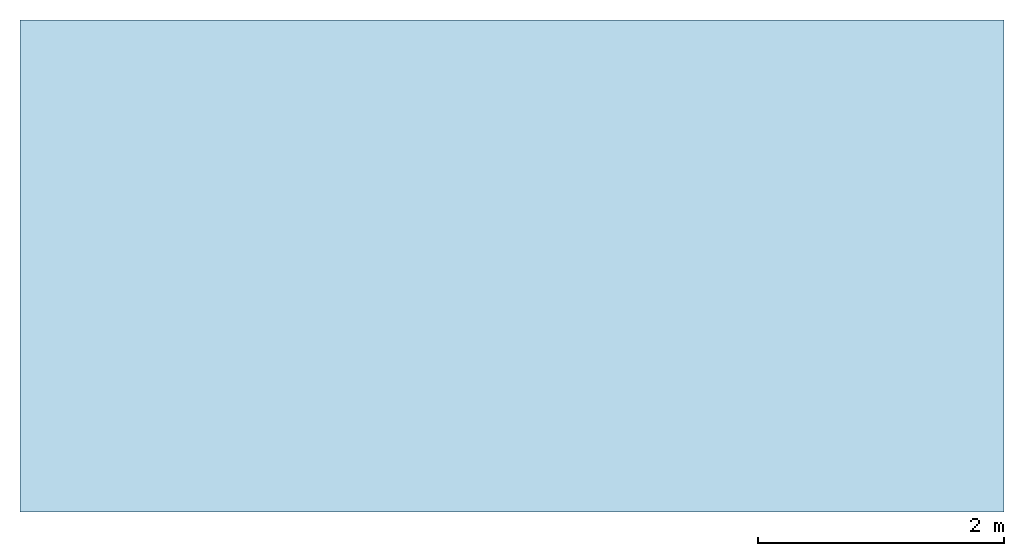
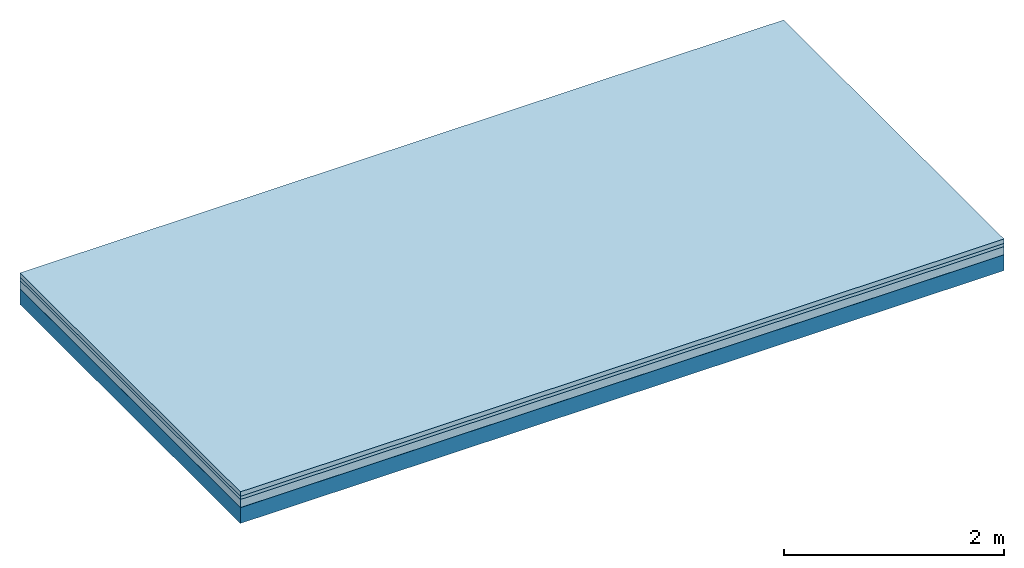
# One storey: 4 plates, 1 member, 1 element without a shape of its own.
"""IFC4 building model written with IfcOpenShell, lengths in metres."""

from ifc_helpers import new_model, si_unit, derived_unit, direction, frame, frame_2d, origin, origin_with_axes, place, context, project, spatial, rectangle, extrude, material, layer, layer_set, type_object, element, aggregate, save


model = new_model("IFC4")

# Units and contexts
plan_context = context("Plan", 3, precision=1e-05, world=origin(), true_north=direction((0.0, 1.0)))
model_context = context("Model", 3, precision=1e-05, world=origin(), true_north=direction((0.0, 1.0)))
ifc_project = project(units=[si_unit("LENGTHUNIT", "METRE"), derived_unit("SOUNDPRESSUREUNIT", [(si_unit("PRESSUREUNIT", "PASCAL", prefix="MICRO"), 0)]), si_unit("ENERGYUNIT", "JOULE", prefix="MEGA"), si_unit("MASSUNIT", "GRAM", prefix="KILO"), derived_unit("THERMALTRANSMITTANCEUNIT", [(si_unit("POWERUNIT", "WATT"), 1), (si_unit("AREAUNIT", "SQUARE_METRE"), -1), (si_unit("THERMODYNAMICTEMPERATUREUNIT", "KELVIN"), -1)]), derived_unit("AREADENSITYUNIT", [(si_unit("MASSUNIT", "GRAM", prefix="KILO"), 1), (si_unit("AREAUNIT", "SQUARE_METRE"), -1)]), derived_unit("USERDEFINED", [(si_unit("ENERGYUNIT", "JOULE", prefix="MEGA"), 1), (si_unit("AREAUNIT", "SQUARE_METRE"), -1)])], contexts=[plan_context, model_context])

# Site, building, storey
site = spatial("IfcSite", under=ifc_project)
building_placement = place(None, origin())
building = spatial("IfcBuilding", under=site, at=building_placement)
storey_placement = place(building_placement, origin())
storey = spatial("IfcBuildingStorey", under=building, at=storey_placement)

# Slab, member, plates
ifc_material_1 = material(Name="Cement screed", Category="04.006")
ifc_layer_1 = layer(ifc_material_1, 0.05, Name="On-material")
ifc_material_2 = material(Name="EP1, 40/35mm")
ifc_layer_2 = layer(ifc_material_2, 0.035, Name="Impact sound insulation")
ifc_material_3 = material(Category="03.011")
ifc_layer_3 = layer(ifc_material_3, 0.09, Name="on Supporting structure")
ifc_material_4 = material(Name="protection", Category="09.007")
ifc_layer_4 = layer(ifc_material_4, 0.0005, Name="Sub-floor")
ifc_material_5 = material(Name="no composite action")
ifc_layer_5 = layer(ifc_material_5, 0.0, Name="Bond")
ifc_layer_6 = layer(None, 0.175, Name="Supporting structure")
ifc_layer_set = layer_set([ifc_layer_1, ifc_layer_2, ifc_layer_3, ifc_layer_4, ifc_layer_5, ifc_layer_6])
slab_type = type_object("IfcSlabType", Name="A2712", PredefinedType="NOTDEFINED", material=ifc_layer_set)
slab_placement = place(None, frame((0.0, 0.0, 0.0), z_axis=(0.0, 0.0, -1.0), x_axis=(1.0, 0.0, 0.0)))
slab = element("IfcSlab", 1, at=slab_placement, inside=storey, type_object=slab_type, material=ifc_layer_set, Name="Slab #1")
ifc_material_6 = material(Name="OSB")
member_placement = place(slab_placement, origin())
member = element("IfcMember", 2, at=member_placement, material=ifc_material_6, Name="Supporting structure", context=plan_context, shape_type="SweptSolid", body=[
    extrude(rectangle(XDim=1.0, YDim=0.175, at=frame_2d((0.5, 0.0875), x_axis=(1.0, 0.0))), frame((0.0, 4.0, 0.1755), z_axis=(0.0, -1.0, 0.0), x_axis=(1.0, 0.0, 0.0)), (0.0, 0.0, 1.0), 4.0),
    extrude(rectangle(XDim=1.0, YDim=0.175, at=frame_2d((0.5, 0.0875), x_axis=(1.0, 0.0))), frame((1.0, 4.0, 0.1755), z_axis=(0.0, -1.0, 0.0), x_axis=(1.0, 0.0, 0.0)), (0.0, 0.0, 1.0), 4.0),
    extrude(rectangle(XDim=1.0, YDim=0.175, at=frame_2d((0.5, 0.0875), x_axis=(1.0, 0.0))), frame((2.0, 4.0, 0.1755), z_axis=(0.0, -1.0, 0.0), x_axis=(1.0, 0.0, 0.0)), (0.0, 0.0, 1.0), 4.0),
    extrude(rectangle(XDim=1.0, YDim=0.175, at=frame_2d((0.5, 0.0875), x_axis=(1.0, 0.0))), frame((3.0, 4.0, 0.1755), z_axis=(0.0, -1.0, 0.0), x_axis=(1.0, 0.0, 0.0)), (0.0, 0.0, 1.0), 4.0),
    extrude(rectangle(XDim=1.0, YDim=0.175, at=frame_2d((0.5, 0.0875), x_axis=(1.0, 0.0))), frame((4.0, 4.0, 0.1755), z_axis=(0.0, -1.0, 0.0), x_axis=(1.0, 0.0, 0.0)), (0.0, 0.0, 1.0), 4.0),
    extrude(rectangle(XDim=1.0, YDim=0.175, at=frame_2d((0.5, 0.0875), x_axis=(1.0, 0.0))), frame((5.0, 4.0, 0.1755), z_axis=(0.0, -1.0, 0.0), x_axis=(1.0, 0.0, 0.0)), (0.0, 0.0, 1.0), 4.0),
    extrude(rectangle(XDim=1.0, YDim=0.175, at=frame_2d((0.5, 0.0875), x_axis=(1.0, 0.0))), frame((6.0, 4.0, 0.1755), z_axis=(0.0, -1.0, 0.0), x_axis=(1.0, 0.0, 0.0)), (0.0, 0.0, 1.0), 4.0),
    extrude(rectangle(XDim=1.0, YDim=0.175, at=frame_2d((0.5, 0.0875), x_axis=(1.0, 0.0))), frame((7.0, 4.0, 0.1755), z_axis=(0.0, -1.0, 0.0), x_axis=(1.0, 0.0, 0.0)), (0.0, 0.0, 1.0), 4.0),
])
plate_1_placement = place(slab_placement, origin())
plate_1 = element("IfcPlate", 3, at=plate_1_placement, material=ifc_material_1, Name="On-material", context=plan_context, shape_type="SweptSolid", body=[
    extrude(rectangle(XDim=8.0, YDim=4.0, at=frame_2d((4.0, 2.0), x_axis=(1.0, 0.0))), origin_with_axes(), (0.0, 0.0, 1.0), 0.05),
])
plate_2_placement = place(slab_placement, origin())
plate_2 = element("IfcPlate", 4, at=plate_2_placement, material=ifc_material_2, Name="Impact sound insulation", context=plan_context, shape_type="SweptSolid", body=[
    extrude(rectangle(XDim=8.0, YDim=4.0, at=frame_2d((4.0, 2.0), x_axis=(1.0, 0.0))), frame((0.0, 0.0, 0.05), z_axis=(0.0, 0.0, 1.0), x_axis=(1.0, 0.0, 0.0)), (0.0, 0.0, 1.0), 0.035),
])
plate_3_placement = place(slab_placement, origin())
plate_3 = element("IfcPlate", 5, at=plate_3_placement, material=ifc_material_3, Name="on Supporting structure", context=plan_context, shape_type="SweptSolid", body=[
    extrude(rectangle(XDim=8.0, YDim=4.0, at=frame_2d((4.0, 2.0), x_axis=(1.0, 0.0))), frame((0.0, 0.0, 0.085), z_axis=(0.0, 0.0, 1.0), x_axis=(1.0, 0.0, 0.0)), (0.0, 0.0, 1.0), 0.09),
])
plate_4_placement = place(slab_placement, origin())
plate_4 = element("IfcPlate", 6, at=plate_4_placement, material=ifc_material_4, Name="Sub-floor", context=plan_context, shape_type="SweptSolid", body=[
    extrude(rectangle(XDim=8.0, YDim=4.0, at=frame_2d((4.0, 2.0), x_axis=(1.0, 0.0))), frame((0.0, 0.0, 0.175), z_axis=(0.0, 0.0, 1.0), x_axis=(1.0, 0.0, 0.0)), (0.0, 0.0, 1.0), 0.0005),
])
aggregate(slab, [plate_1, plate_2, plate_3, plate_4, member])

save(model, "model.ifc")
